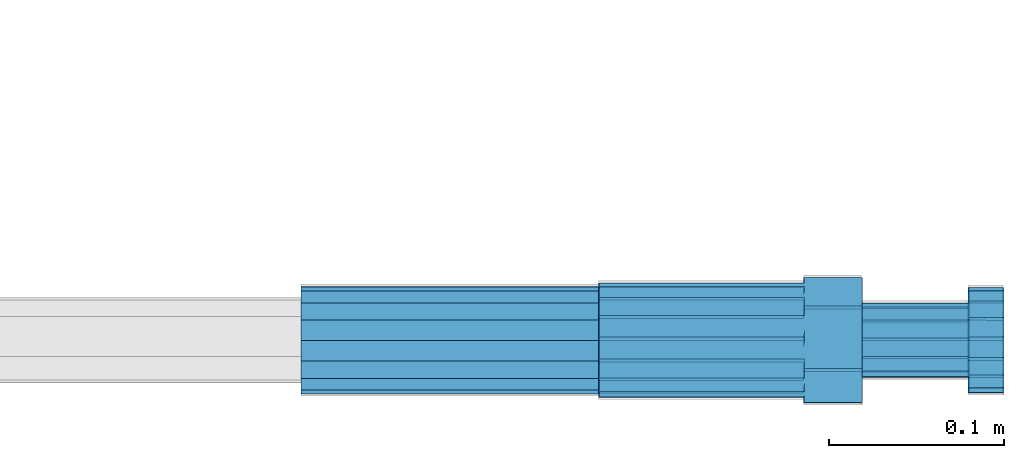
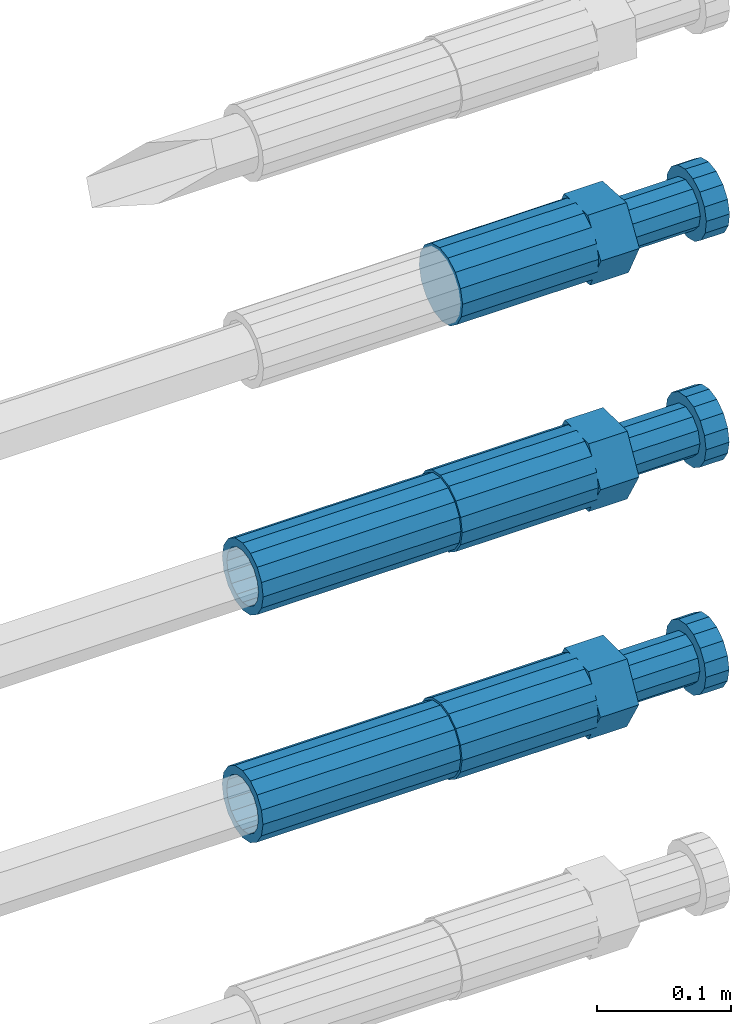
# One storey, part 103 of 177: 5 beams.
"""IFC2X3 building model written with IfcOpenShell, lengths in millimetres."""

from ifc_helpers import new_model, si_unit, frame, origin_with_axes, place, context, subcontext, project, spatial, faceted_brep, material, type_object, element, save


model = new_model("IFC2X3")

# Units and contexts
model_context_1 = context("Model", 3, precision=1e-05, world=origin_with_axes())
model_context_2 = context("Model", 3, precision=1e-05, world=origin_with_axes())
body_context = subcontext(model_context_2, "Body", "Model", "MODEL_VIEW")
ifc_project = project(units=[si_unit("LENGTHUNIT", "METRE", prefix="MILLI"), si_unit("AREAUNIT", "SQUARE_METRE"), si_unit("VOLUMEUNIT", "CUBIC_METRE"), si_unit("MASSUNIT", "GRAM", prefix="KILO"), si_unit("TIMEUNIT", "SECOND"), si_unit("PLANEANGLEUNIT", "RADIAN"), si_unit("SOLIDANGLEUNIT", "STERADIAN"), si_unit("THERMODYNAMICTEMPERATUREUNIT", "DEGREE_CELSIUS"), si_unit("LUMINOUSINTENSITYUNIT", "LUMEN")], contexts=[model_context_1])

# Site, building, storey
site_placement = place(None, origin_with_axes())
site = spatial("IfcSite", under=ifc_project, at=site_placement, CompositionType="ELEMENT")
building_placement = place(site_placement, origin_with_axes())
building = spatial("IfcBuilding", under=site, at=building_placement, Name="Undefined", CompositionType="ELEMENT")
storey_placement = place(building_placement, origin_with_axes())
storey = spatial("IfcBuildingStorey", under=building, at=storey_placement, Name="Undefined", CompositionType="ELEMENT", Elevation=0.0)

# Beams
ifc_material = material(Name="STEEL/S275")
beam_type_1 = type_object("IfcBeamType", PredefinedType="NOTDEFINED")
beam_1_placement = place(storey_placement, frame((2039349.01982224, 6205099.24769776, 20566.5511644244), z_axis=(0.0, 0.00226892700046301, -0.999997425981821), x_axis=(1.0, 0.0, 0.0)))
element("IfcBeam", 1, at=beam_1_placement, inside=storey, type_object=beam_type_1, material=ifc_material, Name="AG40N", context=body_context, shape_type="Brep", body=[
    faceted_brep([(0.0, -23.5000000001164, -9.31322574615479e-10), (0.0, -21.7111690140155, 8.99306066054851), (170.0, -21.7111690140155, 8.99306066054851), (170.0, -23.5, 0.0), (0.0, -16.6170093578839, 16.6170093575493), (170.0, -16.6170093578839, 16.6170093575493), (0.0, -8.99306066057943, 21.7111690137535), (170.0, -8.99306066057943, 21.7111690137535), (0.0, 1.16415321826935e-10, 23.5), (170.0, 0.0, 23.5), (0.0, 8.99306066057943, 21.7111690137535), (170.0, 8.99306066057943, 21.7111690137535), (0.0, 16.6170093578839, 16.6170093575493), (170.0, 16.6170093578839, 16.6170093575493), (0.0, 21.7111690140155, 8.99306066054851), (170.0, 21.7111690140155, 8.99306066054851), (0.0, 23.5000000001164, -9.31322574615479e-10), (170.0, 23.5, 0.0), (0.0, 21.7111690140155, -8.99306066054851), (170.0, 21.7111690140155, -8.99306066054851), (0.0, 16.6170093578839, -16.6170093575493), (170.0, 16.6170093578839, -16.6170093575493), (0.0, 8.99306066057943, -21.7111690137535), (170.0, 8.99306066057943, -21.7111690137535), (0.0, 1.16415321826935e-10, -23.5000000009313), (170.0, 0.0, -23.5), (0.0, -8.99306066057943, -21.7111690137535), (170.0, -8.99306066057943, -21.7111690137535), (0.0, -16.6170093578839, -16.6170093575493), (170.0, -16.6170093578839, -16.6170093575493), (0.0, -21.7111690140155, -8.99306066054851), (170.0, -21.7111690140155, -8.99306066054851), (0.0, -30.5, 0.0), (0.0, -28.1783257415937, -11.6718446873128), (170.0, -28.1783257415937, -11.6718446873128), (170.0, -30.5, 0.0), (0.0, -21.5667568261888, -21.5667568258941), (170.0, -21.5667568261888, -21.5667568258941), (0.0, -11.6718446871346, -28.1783257415518), (170.0, -11.6718446871346, -28.1783257415518), (0.0, 0.0, -30.5), (170.0, 0.0, -30.5), (0.0, 11.6718446871346, -28.1783257415518), (170.0, 11.6718446871346, -28.1783257415518), (0.0, 21.5667568261888, -21.5667568258941), (170.0, 21.5667568261888, -21.5667568258941), (0.0, 28.1783257415937, -11.6718446873128), (170.0, 28.1783257415937, -11.6718446873128), (0.0, 30.5, 0.0), (170.0, 30.5, 0.0), (0.0, 28.1783257415937, 11.6718446873128), (170.0, 28.1783257415937, 11.6718446873128), (0.0, 21.5667568261888, 21.5667568258941), (170.0, 21.5667568261888, 21.5667568258941), (0.0, 11.6718446871346, 28.1783257415518), (170.0, 11.6718446871346, 28.1783257415518), (0.0, 0.0, 30.5), (170.0, 0.0, 30.5), (0.0, -11.6718446871346, 28.1783257415518), (170.0, -11.6718446871346, 28.1783257415518), (0.0, -21.5667568261888, 21.5667568258941), (170.0, -21.5667568261888, 21.5667568258941), (0.0, -28.1783257415937, 11.6718446873128), (170.0, -28.1783257415937, 11.6718446873128)], [[[0, 1, 2, 3]], [[1, 4, 5, 2]], [[4, 6, 7, 5]], [[6, 8, 9, 7]], [[8, 10, 11, 9]], [[10, 12, 13, 11]], [[12, 14, 15, 13]], [[14, 16, 17, 15]], [[16, 18, 19, 17]], [[18, 20, 21, 19]], [[20, 22, 23, 21]], [[22, 24, 25, 23]], [[24, 26, 27, 25]], [[26, 28, 29, 27]], [[28, 30, 31, 29]], [[30, 0, 3, 31]], [[32, 33, 34, 35]], [[33, 36, 37, 34]], [[36, 38, 39, 37]], [[38, 40, 41, 39]], [[40, 42, 43, 41]], [[42, 44, 45, 43]], [[44, 46, 47, 45]], [[46, 48, 49, 47]], [[48, 50, 51, 49]], [[50, 52, 53, 51]], [[52, 54, 55, 53]], [[54, 56, 57, 55]], [[56, 58, 59, 57]], [[58, 60, 61, 59]], [[60, 62, 63, 61]], [[62, 32, 35, 63]], [[37, 39, 41, 43, 45, 47, 49, 51, 53, 55, 57, 59, 61, 63, 35, 34], [5, 7, 9, 11, 13, 15, 17, 19, 21, 23, 25, 27, 29, 31, 3, 2]], [[62, 60, 58, 56, 54, 52, 50, 48, 46, 44, 42, 40, 38, 36, 33, 32], [30, 28, 26, 24, 22, 20, 18, 16, 14, 12, 10, 8, 6, 4, 1, 0]]]),
])
beam_2_placement = place(storey_placement, frame((2039349.01982224, 6205099.48514645, 20359.6003321175), z_axis=(0.0, 0.00575955399777739, -0.99998341363132), x_axis=(1.0, 0.0, 0.0)))
element("IfcBeam", 2, at=beam_2_placement, inside=storey, type_object=beam_type_1, material=ifc_material, Name="AG40N", context=body_context, shape_type="Brep", body=[
    faceted_brep([(0.0, -23.5000000001164, -9.31322574615479e-10), (0.0, -21.7111690140155, 8.99306066054851), (170.0, -21.7111690140155, 8.99306066054851), (170.0, -23.5, 0.0), (0.0, -16.6170093578839, 16.6170093575493), (170.0, -16.6170093578839, 16.6170093575493), (0.0, -8.99306066057943, 21.7111690137535), (170.0, -8.99306066057943, 21.7111690137535), (0.0, 1.16415321826935e-10, 23.5), (170.0, 0.0, 23.5), (0.0, 8.99306066057943, 21.7111690137535), (170.0, 8.99306066057943, 21.7111690137535), (0.0, 16.6170093578839, 16.6170093575493), (170.0, 16.6170093578839, 16.6170093575493), (0.0, 21.7111690140155, 8.99306066054851), (170.0, 21.7111690140155, 8.99306066054851), (0.0, 23.5000000001164, -9.31322574615479e-10), (170.0, 23.5, 0.0), (0.0, 21.7111690140155, -8.99306066054851), (170.0, 21.7111690140155, -8.99306066054851), (0.0, 16.6170093578839, -16.6170093575493), (170.0, 16.6170093578839, -16.6170093575493), (0.0, 8.99306066057943, -21.7111690137535), (170.0, 8.99306066057943, -21.7111690137535), (0.0, 1.16415321826935e-10, -23.5000000009313), (170.0, 0.0, -23.5), (0.0, -8.99306066057943, -21.7111690137535), (170.0, -8.99306066057943, -21.7111690137535), (0.0, -16.6170093578839, -16.6170093575493), (170.0, -16.6170093578839, -16.6170093575493), (0.0, -21.7111690140155, -8.99306066054851), (170.0, -21.7111690140155, -8.99306066054851), (0.0, -30.5, 0.0), (0.0, -28.1783257415937, -11.6718446873128), (170.0, -28.1783257415937, -11.6718446873128), (170.0, -30.5, 0.0), (0.0, -21.5667568261888, -21.5667568258941), (170.0, -21.5667568261888, -21.5667568258941), (0.0, -11.6718446871346, -28.1783257415518), (170.0, -11.6718446871346, -28.1783257415518), (0.0, 0.0, -30.5), (170.0, 0.0, -30.5), (0.0, 11.6718446871346, -28.1783257415518), (170.0, 11.6718446871346, -28.1783257415518), (0.0, 21.5667568261888, -21.5667568258941), (170.0, 21.5667568261888, -21.5667568258941), (0.0, 28.1783257415937, -11.6718446873128), (170.0, 28.1783257415937, -11.6718446873128), (0.0, 30.5, 0.0), (170.0, 30.5, 0.0), (0.0, 28.1783257415937, 11.6718446873128), (170.0, 28.1783257415937, 11.6718446873128), (0.0, 21.5667568261888, 21.5667568258941), (170.0, 21.5667568261888, 21.5667568258941), (0.0, 11.6718446871346, 28.1783257415518), (170.0, 11.6718446871346, 28.1783257415518), (0.0, 0.0, 30.5), (170.0, 0.0, 30.5), (0.0, -11.6718446871346, 28.1783257415518), (170.0, -11.6718446871346, 28.1783257415518), (0.0, -21.5667568261888, 21.5667568258941), (170.0, -21.5667568261888, 21.5667568258941), (0.0, -28.1783257415937, 11.6718446873128), (170.0, -28.1783257415937, 11.6718446873128)], [[[0, 1, 2, 3]], [[1, 4, 5, 2]], [[4, 6, 7, 5]], [[6, 8, 9, 7]], [[8, 10, 11, 9]], [[10, 12, 13, 11]], [[12, 14, 15, 13]], [[14, 16, 17, 15]], [[16, 18, 19, 17]], [[18, 20, 21, 19]], [[20, 22, 23, 21]], [[22, 24, 25, 23]], [[24, 26, 27, 25]], [[26, 28, 29, 27]], [[28, 30, 31, 29]], [[30, 0, 3, 31]], [[32, 33, 34, 35]], [[33, 36, 37, 34]], [[36, 38, 39, 37]], [[38, 40, 41, 39]], [[40, 42, 43, 41]], [[42, 44, 45, 43]], [[44, 46, 47, 45]], [[46, 48, 49, 47]], [[48, 50, 51, 49]], [[50, 52, 53, 51]], [[52, 54, 55, 53]], [[54, 56, 57, 55]], [[56, 58, 59, 57]], [[58, 60, 61, 59]], [[60, 62, 63, 61]], [[62, 32, 35, 63]], [[37, 39, 41, 43, 45, 47, 49, 51, 53, 55, 57, 59, 61, 63, 35, 34], [5, 7, 9, 11, 13, 15, 17, 19, 21, 23, 25, 27, 29, 31, 3, 2]], [[62, 60, 58, 56, 54, 52, 50, 48, 46, 44, 42, 40, 38, 36, 33, 32], [30, 28, 26, 24, 22, 20, 18, 16, 14, 12, 10, 8, 6, 4, 1, 0]]]),
])
beam_type_2 = type_object("IfcBeamType", Name="ROD65", PredefinedType="NOTDEFINED")
beam_3_placement = place(storey_placement, frame((2039519.51584437, 6205099.55100679, 20771.99490671), z_axis=(0.0, -0.0523359559876842, -0.998629534767952), x_axis=(1.0, 0.0, 0.0)))
element("IfcBeam", 3, at=beam_3_placement, inside=storey, type_object=beam_type_2, material=ifc_material, Name="AGB40", ObjectType="ROD65", context=body_context, shape_type="Brep", body=[
    faceted_brep([(117.0, 8.17543110251427, 30.873805644922), (117.0, 17.8250000001863, 30.873805644922), (117.0, 22.0056958701462, 23.6326279877685), (117.0, 12.4372115517035, 30.0260848065373), (117.0, -17.8250000001863, 30.873805644922), (150.200000000186, -17.8250000001863, 30.873805644922), (150.200000000186, 17.8250000001863, 30.873805644922), (117.0, -8.17543110251427, 30.873805644922), (117.0, -12.4372115517035, 30.0260848065373), (117.0, -22.0056958701462, 23.6326279877685), (117.0, -35.6500000003725, 0.0), (150.200000000186, -35.6500000003725, 0.0), (117.0, -30.8443150008097, 8.32369058486074), (117.0, -32.5, 0.0), (117.0, -30.8443150008097, -8.32369058462791), (117.0, -17.8250000001863, -30.873805644922), (150.200000000186, -17.8250000001863, -30.873805644922), (117.0, -22.0056958701462, -23.6326279877685), (117.0, -12.4372115517035, -30.0260848065373), (117.0, -8.17543110251427, -30.873805644922), (117.0, 17.8250000001863, -30.873805644922), (150.200000000186, 17.8250000001863, -30.873805644922), (117.0, 8.17543110251427, -30.873805644922), (117.0, 22.0056958701462, -23.6326279877685), (117.0, 12.4372115517035, -30.0260848065373), (117.0, 35.6500000003725, 0.0), (150.200000000186, 35.6500000003725, 0.0), (117.0, 30.8443150008097, -8.32369058486074), (117.0, 30.8443150008097, 8.32369058462791), (117.0, 32.5, 0.0), (0.0, -22.9809703892097, 22.9809703885621), (0.0, -30.0260848058388, 12.4372115518636), (117.0, -30.0260848067701, 12.4372115519363), (117.0, -22.9809703882784, 22.9809703885112), (-2.3283064365387e-10, 22.9809703892097, -22.9809703885639), (-4.65661287307739e-10, 30.0260848077014, -12.4372115518672), (117.0, 30.0260848067701, -12.4372115519363), (117.0, 22.9809703882784, -22.9809703885112), (-2.3283064365387e-10, -30.0260848067701, -12.4372115518672), (-2.3283064365387e-10, -22.9809703892097, -22.9809703885621), (117.0, -22.9809703882784, -22.9809703885112), (117.0, -30.0260848067701, -12.4372115519363), (-2.3283064365387e-10, -12.4372115507722, 30.0260848066137), (-2.3283064365387e-10, 9.31322574615479e-10, 32.4999999999982), (-2.3283064365387e-10, 12.4372115526348, 30.0260848066137), (0.0, 22.9809703892097, 22.9809703885621), (-2.3283064365387e-10, 30.0260848077014, 12.4372115518636), (-2.3283064365387e-10, 32.5, 0.0), (-2.3283064365387e-10, 12.4372115526348, -30.0260848066173), (-2.3283064365387e-10, 9.31322574615479e-10, -32.5), (-2.3283064365387e-10, -12.4372115517035, -30.0260848066173), (-4.65661287307739e-10, -32.4999999990687, -1.81898940354586e-12), (117.0, 22.9809703882784, 22.9809703885112), (117.0, 30.0260848067701, 12.4372115519363), (117.0, 0.0, -32.5), (117.0, 0.0, 32.5), (150.200000000186, 10.5, -18.1865334794857), (150.200000000186, 0.0, -21.0), (150.200000000186, -10.5, -18.1865334794857), (150.200000000186, -18.18653347902, -10.5), (150.200000000186, -21.0, 0.0), (150.200000000186, -18.18653347902, 10.5), (150.200000000186, -10.5, 18.1865334794857), (150.200000000186, 0.0, 21.0), (150.200000000186, 10.5, 18.1865334794857), (150.200000000186, 18.18653347902, 10.5), (150.200000000186, 21.0, 0.0), (150.200000000186, 18.18653347902, -10.5), (210.980000000447, -18.18653347902, 10.5), (210.980000000447, -21.0, 0.0), (210.980000000447, -10.5, 18.1865334794857), (210.980000000447, 0.0, 21.0), (210.980000000447, 10.5, 18.1865334794857), (210.980000000447, 18.18653347902, 10.5), (210.980000000447, 21.0, 0.0), (210.980000000447, 18.18653347902, -10.5), (210.980000000447, 10.5, -18.1865334794857), (210.980000000447, 0.0, -21.0), (210.980000000447, -10.5, -18.1865334794857), (210.980000000447, -18.18653347902, -10.5), (211.001368442696, -27.7269937992096, -11.491116326768), (211.003082550167, -21.2238094303757, -21.223815418547), (231.002518367059, -21.2131944671273, -21.2132004550658), (231.000804259587, -27.7163788359612, -11.4805013632867), (211.001368440451, -11.4911085031927, -27.7269970395137), (231.000804257343, -11.4804935399443, -27.7163820760325), (210.996487071217, -0.0106065049767494, -30.0106107392348), (230.995922888109, 8.45827162265778e-06, -29.9999957757536), (210.989181586672, 11.46989420522, -27.7269970329944), (230.988617403564, 11.4805091684684, -27.7163820695132), (210.980564180623, 21.2025914648548, -21.2238154064398), (230.979999997515, 21.2132064281031, -21.2132004429586), (210.971946775022, 27.7057703435421, -11.4911163107026), (230.971382591913, 27.7163853067905, -11.4805013472214), (210.96464129175, 29.9893808094785, -0.0106149562634528), (230.964077108642, 29.9999957727268, 7.21774995326996e-09), (210.959759924415, 27.7057638689876, 11.4698863970116), (230.959195741307, 27.7163788322359, 11.4805013604928), (210.958045816944, 21.2025795001537, 21.2025854887906), (230.957481633835, 21.213194463402, 21.2132004522718), (210.95975992666, 11.4698785729706, 27.7057671097573), (230.959195743551, 11.480493536219, 27.7163820732385), (210.964641295894, -0.010623425245285, 29.9893808094785), (230.964077112785, -8.46199691295624e-06, 29.9999957729597), (210.971946780439, -11.4911241354421, 27.705767103238), (230.97138259733, -11.4805091721937, 27.7163820667192), (210.980564186488, -21.2238213950768, 21.2025854766835), (230.980000003379, -21.2132064318284, 21.2132004401647), (210.989181592089, -27.7270002737641, 11.4698863809463), (230.988617408981, -27.7163853105158, 11.4805013444275), (210.996487075361, -30.0106107397005, -0.0106149734929204), (230.995922892253, -29.9999957764521, -1.00117176771164e-08)], [[[0, 1, 2, 3]], [[4, 5, 6, 1, 0, 7]], [[4, 7, 8, 9]], [[10, 11, 5, 4, 9, 12]], [[10, 12, 13, 14]], [[15, 16, 11, 10, 14, 17]], [[15, 17, 18, 19]], [[20, 21, 16, 15, 19, 22]], [[23, 20, 22, 24]], [[25, 26, 21, 20, 23, 27]], [[28, 25, 27, 29]], [[30, 31, 32, 33]], [[34, 35, 36, 37]], [[38, 39, 40, 41]], [[31, 30, 42, 43, 44, 45, 46, 47, 35, 34, 48, 49, 50, 39, 38, 51]], [[46, 45, 52, 53]], [[29, 47, 46, 53, 28]], [[27, 36, 35, 47, 29]], [[23, 37, 36, 27]], [[24, 48, 34, 37, 23]], [[22, 54, 49, 48, 24]], [[19, 54, 22]], [[18, 50, 49, 54, 19]], [[17, 40, 39, 50, 18]], [[14, 41, 40, 17]], [[13, 51, 38, 41, 14]], [[12, 32, 31, 51, 13]], [[9, 33, 32, 12]], [[8, 42, 30, 33, 9]], [[7, 55, 43, 42, 8]], [[0, 55, 7]], [[3, 44, 43, 55, 0]], [[2, 52, 45, 44, 3]], [[28, 53, 52, 2]], [[1, 6, 26, 25, 28, 2]], [[5, 11, 16, 21, 26, 6], [56, 57, 58, 59, 60, 61, 62, 63, 64, 65, 66, 67]], [[68, 61, 60, 69]], [[70, 62, 61, 68]], [[71, 63, 62, 70]], [[72, 64, 63, 71]], [[73, 65, 64, 72]], [[74, 66, 65, 73]], [[75, 67, 66, 74]], [[76, 56, 67, 75]], [[77, 57, 56, 76]], [[78, 58, 57, 77]], [[79, 59, 58, 78]], [[69, 60, 59, 79]], [[80, 81, 82, 83]], [[81, 84, 85, 82]], [[84, 86, 87, 85]], [[86, 88, 89, 87]], [[88, 90, 91, 89]], [[90, 92, 93, 91]], [[92, 94, 95, 93]], [[94, 96, 97, 95]], [[96, 98, 99, 97]], [[98, 100, 101, 99]], [[100, 102, 103, 101]], [[102, 104, 105, 103]], [[104, 106, 107, 105]], [[106, 108, 109, 107]], [[108, 110, 111, 109]], [[82, 85, 87, 89, 91, 93, 95, 97, 99, 101, 103, 105, 107, 109, 111, 83]], [[110, 80, 83, 111]], [[108, 106, 104, 102, 100, 98, 96, 94, 92, 90, 88, 86, 84, 81, 80, 110], [75, 74, 73, 72, 71, 70, 68, 69, 79, 78, 77, 76]]]),
])
beam_4_placement = place(storey_placement, frame((2039519.01982224, 6205099.24769775, 20566.5511644228), z_axis=(0.0, 0.00226892700046301, -0.999997425981821), x_axis=(1.0, 0.0, 0.0)))
element("IfcBeam", 4, at=beam_4_placement, inside=storey, type_object=beam_type_2, material=ifc_material, Name="AGB40", ObjectType="ROD65", context=body_context, shape_type="Brep", body=[
    faceted_brep([(117.0, 8.17543110251427, 30.873805644922), (117.0, 17.8250000001863, 30.873805644922), (117.0, 22.0056958701462, 23.6326279877685), (117.0, 12.4372115517035, 30.0260848065373), (117.0, -17.8250000001863, 30.873805644922), (150.200000000186, -17.8250000001863, 30.873805644922), (150.200000000186, 17.8250000001863, 30.873805644922), (117.0, -8.17543110251427, 30.873805644922), (117.0, -12.4372115517035, 30.0260848065373), (117.0, -22.0056958701462, 23.6326279877685), (117.0, -35.6500000003725, 0.0), (150.200000000186, -35.6500000003725, 0.0), (117.0, -30.8443150008097, 8.32369058486074), (117.0, -32.5, 0.0), (117.0, -30.8443150008097, -8.32369058462791), (117.0, -17.8250000001863, -30.873805644922), (150.200000000186, -17.8250000001863, -30.873805644922), (117.0, -22.0056958701462, -23.6326279877685), (117.0, -12.4372115517035, -30.0260848065373), (117.0, -8.17543110251427, -30.873805644922), (117.0, 17.8250000001863, -30.873805644922), (150.200000000186, 17.8250000001863, -30.873805644922), (117.0, 8.17543110251427, -30.873805644922), (117.0, 22.0056958701462, -23.6326279877685), (117.0, 12.4372115517035, -30.0260848065373), (117.0, 35.6500000003725, 0.0), (150.200000000186, 35.6500000003725, 0.0), (117.0, 30.8443150008097, -8.32369058486074), (117.0, 30.8443150008097, 8.32369058462791), (117.0, 32.5, 0.0), (0.0, -22.9809703892097, 22.9809703885621), (0.0, -30.0260848058388, 12.4372115518636), (117.0, -30.0260848067701, 12.4372115519363), (117.0, -22.9809703882784, 22.9809703885112), (-2.3283064365387e-10, 22.9809703892097, -22.9809703885639), (-4.65661287307739e-10, 30.0260848077014, -12.4372115518672), (117.0, 30.0260848067701, -12.4372115519363), (117.0, 22.9809703882784, -22.9809703885112), (-2.3283064365387e-10, -30.0260848067701, -12.4372115518672), (-2.3283064365387e-10, -22.9809703892097, -22.9809703885621), (117.0, -22.9809703882784, -22.9809703885112), (117.0, -30.0260848067701, -12.4372115519363), (-2.3283064365387e-10, -12.4372115507722, 30.0260848066137), (-2.3283064365387e-10, 9.31322574615479e-10, 32.4999999999982), (-2.3283064365387e-10, 12.4372115526348, 30.0260848066137), (0.0, 22.9809703892097, 22.9809703885621), (-2.3283064365387e-10, 30.0260848077014, 12.4372115518636), (-2.3283064365387e-10, 32.5, 0.0), (-2.3283064365387e-10, 12.4372115526348, -30.0260848066173), (-2.3283064365387e-10, 9.31322574615479e-10, -32.5), (-2.3283064365387e-10, -12.4372115517035, -30.0260848066173), (-4.65661287307739e-10, -32.4999999990687, -1.81898940354586e-12), (117.0, 22.9809703882784, 22.9809703885112), (117.0, 30.0260848067701, 12.4372115519363), (117.0, 0.0, -32.5), (117.0, 0.0, 32.5), (150.200000000186, 10.5, -18.1865334794857), (150.200000000186, 0.0, -21.0), (150.200000000186, -10.5, -18.1865334794857), (150.200000000186, -18.18653347902, -10.5), (150.200000000186, -21.0, 0.0), (150.200000000186, -18.18653347902, 10.5), (150.200000000186, -10.5, 18.1865334794857), (150.200000000186, 0.0, 21.0), (150.200000000186, 10.5, 18.1865334794857), (150.200000000186, 18.18653347902, 10.5), (150.200000000186, 21.0, 0.0), (150.200000000186, 18.18653347902, -10.5), (210.980000000447, -18.18653347902, 10.5), (210.980000000447, -21.0, 0.0), (210.980000000447, -10.5, 18.1865334794857), (210.980000000447, 0.0, 21.0), (210.980000000447, 10.5, 18.1865334794857), (210.980000000447, 18.18653347902, 10.5), (210.980000000447, 21.0, 0.0), (210.980000000447, 18.18653347902, -10.5), (210.980000000447, 10.5, -18.1865334794857), (210.980000000447, 0.0, -21.0), (210.980000000447, -10.5, -18.1865334794857), (210.980000000447, -18.18653347902, -10.5), (211.001368442696, -27.7269937992096, -11.491116326768), (211.003082550167, -21.2238094303757, -21.223815418547), (231.002518367059, -21.2131944671273, -21.2132004550658), (231.000804259587, -27.7163788359612, -11.4805013632867), (211.001368440451, -11.4911085031927, -27.7269970395137), (231.000804257343, -11.4804935399443, -27.7163820760325), (210.996487071217, -0.0106065049767494, -30.0106107392348), (230.995922888109, 8.45827162265778e-06, -29.9999957757536), (210.989181586672, 11.46989420522, -27.7269970329944), (230.988617403564, 11.4805091684684, -27.7163820695132), (210.980564180623, 21.2025914648548, -21.2238154064398), (230.979999997515, 21.2132064281031, -21.2132004429586), (210.971946775022, 27.7057703435421, -11.4911163107026), (230.971382591913, 27.7163853067905, -11.4805013472214), (210.96464129175, 29.9893808094785, -0.0106149562634528), (230.964077108642, 29.9999957727268, 7.21774995326996e-09), (210.959759924415, 27.7057638689876, 11.4698863970116), (230.959195741307, 27.7163788322359, 11.4805013604928), (210.958045816944, 21.2025795001537, 21.2025854887906), (230.957481633835, 21.213194463402, 21.2132004522718), (210.95975992666, 11.4698785729706, 27.7057671097573), (230.959195743551, 11.480493536219, 27.7163820732385), (210.964641295894, -0.010623425245285, 29.9893808094785), (230.964077112785, -8.46199691295624e-06, 29.9999957729597), (210.971946780439, -11.4911241354421, 27.705767103238), (230.97138259733, -11.4805091721937, 27.7163820667192), (210.980564186488, -21.2238213950768, 21.2025854766835), (230.980000003379, -21.2132064318284, 21.2132004401647), (210.989181592089, -27.7270002737641, 11.4698863809463), (230.988617408981, -27.7163853105158, 11.4805013444275), (210.996487075361, -30.0106107397005, -0.0106149734929204), (230.995922892253, -29.9999957764521, -1.00117176771164e-08)], [[[0, 1, 2, 3]], [[4, 5, 6, 1, 0, 7]], [[4, 7, 8, 9]], [[10, 11, 5, 4, 9, 12]], [[10, 12, 13, 14]], [[15, 16, 11, 10, 14, 17]], [[15, 17, 18, 19]], [[20, 21, 16, 15, 19, 22]], [[23, 20, 22, 24]], [[25, 26, 21, 20, 23, 27]], [[28, 25, 27, 29]], [[30, 31, 32, 33]], [[34, 35, 36, 37]], [[38, 39, 40, 41]], [[31, 30, 42, 43, 44, 45, 46, 47, 35, 34, 48, 49, 50, 39, 38, 51]], [[46, 45, 52, 53]], [[29, 47, 46, 53, 28]], [[27, 36, 35, 47, 29]], [[23, 37, 36, 27]], [[24, 48, 34, 37, 23]], [[22, 54, 49, 48, 24]], [[19, 54, 22]], [[18, 50, 49, 54, 19]], [[17, 40, 39, 50, 18]], [[14, 41, 40, 17]], [[13, 51, 38, 41, 14]], [[12, 32, 31, 51, 13]], [[9, 33, 32, 12]], [[8, 42, 30, 33, 9]], [[7, 55, 43, 42, 8]], [[0, 55, 7]], [[3, 44, 43, 55, 0]], [[2, 52, 45, 44, 3]], [[28, 53, 52, 2]], [[1, 6, 26, 25, 28, 2]], [[5, 11, 16, 21, 26, 6], [56, 57, 58, 59, 60, 61, 62, 63, 64, 65, 66, 67]], [[68, 61, 60, 69]], [[70, 62, 61, 68]], [[71, 63, 62, 70]], [[72, 64, 63, 71]], [[73, 65, 64, 72]], [[74, 66, 65, 73]], [[75, 67, 66, 74]], [[76, 56, 67, 75]], [[77, 57, 56, 76]], [[78, 58, 57, 77]], [[79, 59, 58, 78]], [[69, 60, 59, 79]], [[80, 81, 82, 83]], [[81, 84, 85, 82]], [[84, 86, 87, 85]], [[86, 88, 89, 87]], [[88, 90, 91, 89]], [[90, 92, 93, 91]], [[92, 94, 95, 93]], [[94, 96, 97, 95]], [[96, 98, 99, 97]], [[98, 100, 101, 99]], [[100, 102, 103, 101]], [[102, 104, 105, 103]], [[104, 106, 107, 105]], [[106, 108, 109, 107]], [[108, 110, 111, 109]], [[82, 85, 87, 89, 91, 93, 95, 97, 99, 101, 103, 105, 107, 109, 111, 83]], [[110, 80, 83, 111]], [[108, 106, 104, 102, 100, 98, 96, 94, 92, 90, 88, 86, 84, 81, 80, 110], [75, 74, 73, 72, 71, 70, 68, 69, 79, 78, 77, 76]]]),
])
beam_5_placement = place(storey_placement, frame((2039519.01982224, 6205099.48514644, 20359.6003321156), z_axis=(0.0, 0.00575955399777739, -0.99998341363132), x_axis=(1.0, 0.0, 0.0)))
element("IfcBeam", 5, at=beam_5_placement, inside=storey, type_object=beam_type_2, material=ifc_material, Name="AGB40", ObjectType="ROD65", context=body_context, shape_type="Brep", body=[
    faceted_brep([(117.0, 8.17543110251427, 30.873805644922), (117.0, 17.8250000001863, 30.873805644922), (117.0, 22.0056958701462, 23.6326279877685), (117.0, 12.4372115517035, 30.0260848065373), (117.0, -17.8250000001863, 30.873805644922), (150.200000000186, -17.8250000001863, 30.873805644922), (150.200000000186, 17.8250000001863, 30.873805644922), (117.0, -8.17543110251427, 30.873805644922), (117.0, -12.4372115517035, 30.0260848065373), (117.0, -22.0056958701462, 23.6326279877685), (117.0, -35.6500000003725, 0.0), (150.200000000186, -35.6500000003725, 0.0), (117.0, -30.8443150008097, 8.32369058486074), (117.0, -32.5, 0.0), (117.0, -30.8443150008097, -8.32369058462791), (117.0, -17.8250000001863, -30.873805644922), (150.200000000186, -17.8250000001863, -30.873805644922), (117.0, -22.0056958701462, -23.6326279877685), (117.0, -12.4372115517035, -30.0260848065373), (117.0, -8.17543110251427, -30.873805644922), (117.0, 17.8250000001863, -30.873805644922), (150.200000000186, 17.8250000001863, -30.873805644922), (117.0, 8.17543110251427, -30.873805644922), (117.0, 22.0056958701462, -23.6326279877685), (117.0, 12.4372115517035, -30.0260848065373), (117.0, 35.6500000003725, 0.0), (150.200000000186, 35.6500000003725, 0.0), (117.0, 30.8443150008097, -8.32369058486074), (117.0, 30.8443150008097, 8.32369058462791), (117.0, 32.5, 0.0), (0.0, -22.9809703892097, 22.9809703885621), (0.0, -30.0260848058388, 12.4372115518636), (117.0, -30.0260848067701, 12.4372115519363), (117.0, -22.9809703882784, 22.9809703885112), (-2.3283064365387e-10, 22.9809703892097, -22.9809703885639), (-4.65661287307739e-10, 30.0260848077014, -12.4372115518672), (117.0, 30.0260848067701, -12.4372115519363), (117.0, 22.9809703882784, -22.9809703885112), (-2.3283064365387e-10, -30.0260848067701, -12.4372115518672), (-2.3283064365387e-10, -22.9809703892097, -22.9809703885621), (117.0, -22.9809703882784, -22.9809703885112), (117.0, -30.0260848067701, -12.4372115519363), (-2.3283064365387e-10, -12.4372115507722, 30.0260848066137), (-2.3283064365387e-10, 9.31322574615479e-10, 32.4999999999982), (-2.3283064365387e-10, 12.4372115526348, 30.0260848066137), (0.0, 22.9809703892097, 22.9809703885621), (-2.3283064365387e-10, 30.0260848077014, 12.4372115518636), (-2.3283064365387e-10, 32.5, 0.0), (-2.3283064365387e-10, 12.4372115526348, -30.0260848066173), (-2.3283064365387e-10, 9.31322574615479e-10, -32.5), (-2.3283064365387e-10, -12.4372115517035, -30.0260848066173), (-4.65661287307739e-10, -32.4999999990687, -1.81898940354586e-12), (117.0, 22.9809703882784, 22.9809703885112), (117.0, 30.0260848067701, 12.4372115519363), (117.0, 0.0, -32.5), (117.0, 0.0, 32.5), (150.200000000186, 10.5, -18.1865334794857), (150.200000000186, 0.0, -21.0), (150.200000000186, -10.5, -18.1865334794857), (150.200000000186, -18.18653347902, -10.5), (150.200000000186, -21.0, 0.0), (150.200000000186, -18.18653347902, 10.5), (150.200000000186, -10.5, 18.1865334794857), (150.200000000186, 0.0, 21.0), (150.200000000186, 10.5, 18.1865334794857), (150.200000000186, 18.18653347902, 10.5), (150.200000000186, 21.0, 0.0), (150.200000000186, 18.18653347902, -10.5), (210.980000000447, -18.18653347902, 10.5), (210.980000000447, -21.0, 0.0), (210.980000000447, -10.5, 18.1865334794857), (210.980000000447, 0.0, 21.0), (210.980000000447, 10.5, 18.1865334794857), (210.980000000447, 18.18653347902, 10.5), (210.980000000447, 21.0, 0.0), (210.980000000447, 18.18653347902, -10.5), (210.980000000447, 10.5, -18.1865334794857), (210.980000000447, 0.0, -21.0), (210.980000000447, -10.5, -18.1865334794857), (210.980000000447, -18.18653347902, -10.5), (211.001368442696, -27.7269937992096, -11.491116326768), (211.003082550167, -21.2238094303757, -21.223815418547), (231.002518367059, -21.2131944671273, -21.2132004550658), (231.000804259587, -27.7163788359612, -11.4805013632867), (211.001368440451, -11.4911085031927, -27.7269970395137), (231.000804257343, -11.4804935399443, -27.7163820760325), (210.996487071217, -0.0106065049767494, -30.0106107392348), (230.995922888109, 8.45827162265778e-06, -29.9999957757536), (210.989181586672, 11.46989420522, -27.7269970329944), (230.988617403564, 11.4805091684684, -27.7163820695132), (210.980564180623, 21.2025914648548, -21.2238154064398), (230.979999997515, 21.2132064281031, -21.2132004429586), (210.971946775022, 27.7057703435421, -11.4911163107026), (230.971382591913, 27.7163853067905, -11.4805013472214), (210.96464129175, 29.9893808094785, -0.0106149562634528), (230.964077108642, 29.9999957727268, 7.21774995326996e-09), (210.959759924415, 27.7057638689876, 11.4698863970116), (230.959195741307, 27.7163788322359, 11.4805013604928), (210.958045816944, 21.2025795001537, 21.2025854887906), (230.957481633835, 21.213194463402, 21.2132004522718), (210.95975992666, 11.4698785729706, 27.7057671097573), (230.959195743551, 11.480493536219, 27.7163820732385), (210.964641295894, -0.010623425245285, 29.9893808094785), (230.964077112785, -8.46199691295624e-06, 29.9999957729597), (210.971946780439, -11.4911241354421, 27.705767103238), (230.97138259733, -11.4805091721937, 27.7163820667192), (210.980564186488, -21.2238213950768, 21.2025854766835), (230.980000003379, -21.2132064318284, 21.2132004401647), (210.989181592089, -27.7270002737641, 11.4698863809463), (230.988617408981, -27.7163853105158, 11.4805013444275), (210.996487075361, -30.0106107397005, -0.0106149734929204), (230.995922892253, -29.9999957764521, -1.00117176771164e-08)], [[[0, 1, 2, 3]], [[4, 5, 6, 1, 0, 7]], [[4, 7, 8, 9]], [[10, 11, 5, 4, 9, 12]], [[10, 12, 13, 14]], [[15, 16, 11, 10, 14, 17]], [[15, 17, 18, 19]], [[20, 21, 16, 15, 19, 22]], [[23, 20, 22, 24]], [[25, 26, 21, 20, 23, 27]], [[28, 25, 27, 29]], [[30, 31, 32, 33]], [[34, 35, 36, 37]], [[38, 39, 40, 41]], [[31, 30, 42, 43, 44, 45, 46, 47, 35, 34, 48, 49, 50, 39, 38, 51]], [[46, 45, 52, 53]], [[29, 47, 46, 53, 28]], [[27, 36, 35, 47, 29]], [[23, 37, 36, 27]], [[24, 48, 34, 37, 23]], [[22, 54, 49, 48, 24]], [[19, 54, 22]], [[18, 50, 49, 54, 19]], [[17, 40, 39, 50, 18]], [[14, 41, 40, 17]], [[13, 51, 38, 41, 14]], [[12, 32, 31, 51, 13]], [[9, 33, 32, 12]], [[8, 42, 30, 33, 9]], [[7, 55, 43, 42, 8]], [[0, 55, 7]], [[3, 44, 43, 55, 0]], [[2, 52, 45, 44, 3]], [[28, 53, 52, 2]], [[1, 6, 26, 25, 28, 2]], [[5, 11, 16, 21, 26, 6], [56, 57, 58, 59, 60, 61, 62, 63, 64, 65, 66, 67]], [[68, 61, 60, 69]], [[70, 62, 61, 68]], [[71, 63, 62, 70]], [[72, 64, 63, 71]], [[73, 65, 64, 72]], [[74, 66, 65, 73]], [[75, 67, 66, 74]], [[76, 56, 67, 75]], [[77, 57, 56, 76]], [[78, 58, 57, 77]], [[79, 59, 58, 78]], [[69, 60, 59, 79]], [[80, 81, 82, 83]], [[81, 84, 85, 82]], [[84, 86, 87, 85]], [[86, 88, 89, 87]], [[88, 90, 91, 89]], [[90, 92, 93, 91]], [[92, 94, 95, 93]], [[94, 96, 97, 95]], [[96, 98, 99, 97]], [[98, 100, 101, 99]], [[100, 102, 103, 101]], [[102, 104, 105, 103]], [[104, 106, 107, 105]], [[106, 108, 109, 107]], [[108, 110, 111, 109]], [[82, 85, 87, 89, 91, 93, 95, 97, 99, 101, 103, 105, 107, 109, 111, 83]], [[110, 80, 83, 111]], [[108, 106, 104, 102, 100, 98, 96, 94, 92, 90, 88, 86, 84, 81, 80, 110], [75, 74, 73, 72, 71, 70, 68, 69, 79, 78, 77, 76]]]),
])

save(model, "model.ifc")
